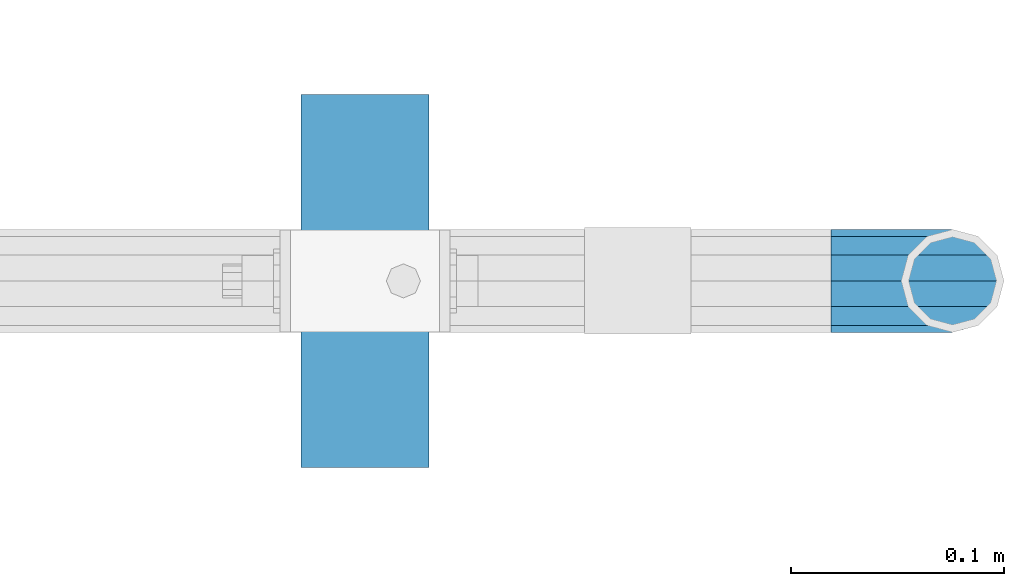
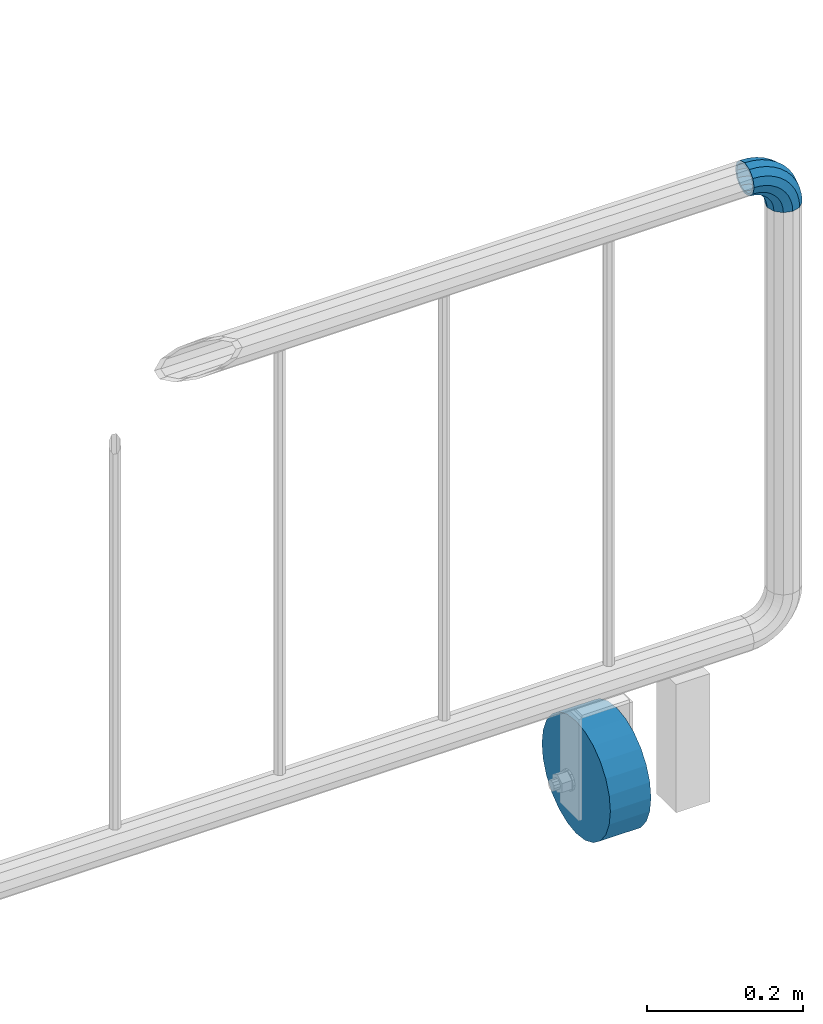
# One storey, part 148 of 208: 1 beam, 1 member.
"""IFC2X3 building model written with IfcOpenShell, lengths in millimetres."""

from ifc_helpers import new_model, si_unit, frame, origin_with_axes, place, context, subcontext, project, spatial, faceted_brep, material, type_object, element, save


model = new_model("IFC2X3")

# Units and contexts
model_context = context("Model", 3, precision=1e-05, world=origin_with_axes())
body_context = subcontext(model_context, "Body", "Model", "MODEL_VIEW")
ifc_project = project(units=[si_unit("LENGTHUNIT", "METRE", prefix="MILLI"), si_unit("AREAUNIT", "SQUARE_METRE"), si_unit("VOLUMEUNIT", "CUBIC_METRE"), si_unit("MASSUNIT", "GRAM", prefix="KILO"), si_unit("TIMEUNIT", "SECOND"), si_unit("PLANEANGLEUNIT", "RADIAN"), si_unit("SOLIDANGLEUNIT", "STERADIAN"), si_unit("THERMODYNAMICTEMPERATUREUNIT", "DEGREE_CELSIUS"), si_unit("LUMINOUSINTENSITYUNIT", "LUMEN")], contexts=[model_context])

# Site, building, storey
site_placement = place(None, origin_with_axes())
site = spatial("IfcSite", under=ifc_project, at=site_placement, CompositionType="ELEMENT")
building_placement = place(site_placement, origin_with_axes())
building = spatial("IfcBuilding", under=site, at=building_placement, Name="Standard", CompositionType="ELEMENT")
storey_placement = place(building_placement, origin_with_axes())
storey = spatial("IfcBuildingStorey", under=building, at=storey_placement, Name="Undefined", CompositionType="ELEMENT", Elevation=0.0)

# Member
ifc_material_1 = material()
member_type = type_object("IfcMemberType", PredefinedType="NOTDEFINED")
member_placement = place(storey_placement, frame((-12177.0539762199, 2941.85399999618, 935.350000000009), z_axis=(0.0, -1.0, 0.0), x_axis=(0.707106781186548, 0.0, -0.707106781186548)))
element("IfcMember", 1, at=member_placement, inside=storey, type_object=member_type, material=ifc_material_1, context=body_context, shape_type="Brep", body=[
    faceted_brep([(17.0766287656552, -17.0766287656552, 0.0), (14.7887943220539, -14.7887943220539, -12.0749999999998), (19.0945697419538, -11.1113146999724, -12.0749999999998), (20.9963409898282, -13.7288782624146, 0.0), (8.53831438282759, -8.53831438282759, -20.9145135013941), (13.8988340683954, -3.95999805533756, -20.9145135013941), (0.0, 0.0, -24.1500000000001), (6.80132714696265, 5.80888215173945, -24.1500000000001), (-8.53831438282759, 8.53831438282759, -20.9145135013941), (-0.296179774470147, 15.5777623588165, -20.9145135013941), (-14.7887943220521, 14.7887943220521, -12.0749999999998), (-5.49191544802852, 22.7290790034513, -12.0749999999998), (-17.0766287656552, 17.0766287656552, 0.0), (-7.39368669589931, 25.3466425658935, 0.0), (-14.7887943220521, 14.7887943220521, 12.0749999999998), (-5.49191544802852, 22.7290790034513, 12.0749999999998), (-8.53831438282759, 8.53831438282759, 20.9145135013941), (-0.296179774470147, 15.5777623588165, 20.9145135013941), (0.0, 0.0, 24.1500000000001), (6.80132714696265, 5.80888215173945, 24.1500000000001), (8.53831438282759, -8.53831438282759, 20.9145135013941), (13.8988340683954, -3.95999805533756, 20.9145135013941), (14.7887943220539, -14.7887943220539, 12.0749999999998), (19.0945697419538, -11.1113146999724, 12.0749999999998), (14.5310443533836, -14.5310443533836, 0.0), (12.5842535535485, -12.5842535535485, 10.2750000000001), (17.2620366843166, -8.58904933077247, 10.2750000000001), (18.8803140815726, -10.8164170826676, 0.0), (7.26552217669268, -7.26552217669268, 17.7968220477701), (12.8408206142685, -2.50376746546499, 17.7968220477701), (0.0, 0.0, 20.5500000000002), (6.80132714696265, 5.80888215173945, 20.5500000000002), (-7.26552217669087, 7.26552217669087, 17.7968220477701), (0.761833679658594, 14.1215317689421, 17.7968220477701), (-12.5842535535485, 12.5842535535485, 10.2750000000001), (-3.65938239039133, 20.2068136342514, 10.2750000000001), (-14.5310443533836, 14.5310443533836, 0.0), (-5.27765978764546, 22.4341813861447, 0.0), (-12.5842535535485, 12.5842535535485, -10.2750000000001), (-3.65938239039133, 20.2068136342514, -10.2750000000001), (-7.26552217669087, 7.26552217669087, -17.7968220477701), (0.761833679658594, 14.1215317689421, -17.7968220477701), (0.0, 0.0, -20.5500000000002), (6.80132714696265, 5.80888215173945, -20.5500000000002), (7.26552217669268, -7.26552217669268, -17.7968220477701), (12.8408206142685, -2.50376746546499, -17.7968220477701), (12.5842535535485, -12.5842535535485, -10.2750000000001), (17.2620366843166, -8.58904933077247, -10.2750000000001), (23.9226184787876, -8.15268262886457, -12.0749999999998), (25.3914986111904, -11.0355222080452, 0.0), (19.9095633268353, -0.27661842847192, -20.9145135013941), (14.4276280424801, 10.482285351105, -24.1500000000001), (8.94569275812501, 21.2411891306783, -20.9145135013941), (4.93263760617265, 29.117253331071, -12.0749999999998), (3.46375747377169, 32.0000929102534, 0.0), (4.93263760617265, 29.117253331071, 12.0749999999998), (8.94569275812501, 21.2411891306783, 20.9145135013941), (14.4276280424801, 10.482285351105, 24.1500000000001), (19.9095633268353, -0.27661842847192, 20.9145135013941), (23.9226184787876, -8.15268262886457, 12.0749999999998), (22.5072161777225, -5.3747992032786, 10.2750000000001), (23.7571328121267, -7.82789872096691, 0.0), (19.0923804273043, 1.32719331506814, 17.7968220477701), (14.4276280424801, 10.482285351105, 20.5500000000002), (9.76287565765597, 19.6373773871383, 17.7968220477701), (6.34803990723776, 26.3393699054886, 10.2750000000001), (5.0981232728318, 28.7924694231751, 0.0), (6.34803990723776, 26.3393699054886, -10.2750000000001), (9.76287565765597, 19.6373773871383, -17.7968220477701), (14.4276280424801, 10.482285351105, -20.5500000000002), (19.0923804273043, 1.32719331506814, -17.7968220477701), (22.5072161777225, -5.3747992032786, -10.2750000000001), (29.1540579492776, -5.98574944945176, -12.0749999999998), (30.1538782624175, -9.06287996733772, 0.0), (26.422498055339, 2.42112746692692, -20.9145135013941), (22.6911178482624, 13.9051349011897, -24.1500000000001), (18.9597376411857, 25.3891423354562, -20.9145135013941), (16.2281777472472, 33.7960192518349, -12.0749999999998), (15.2283574341091, 36.873149769719, 0.0), (16.2281777472472, 33.7960192518349, 12.0749999999998), (18.9597376411857, 25.3891423354562, 20.9145135013941), (22.6911178482624, 13.9051349011897, 24.1500000000001), (26.422498055339, 2.42112746692692, 20.9145135013941), (29.1540579492776, -5.98574944945176, 12.0749999999998), (28.1906383068908, -3.0206486766856, 10.2750000000001), (29.041417082668, -5.63907650867441, 0.0), (25.8662674654661, 4.13302919625858, 17.7968220477701), (22.6911178482624, 13.9051349011897, 20.5500000000002), (19.5159682310605, 23.6772406061227, 17.7968220477701), (17.1915973896339, 30.8309184790687, 10.2750000000001), (16.3408186138568, 33.4493463110575, 0.0), (17.1915973896339, 30.8309184790687, -10.2750000000001), (19.5159682310605, 23.6772406061227, -17.7968220477701), (22.6911178482624, 13.9051349011897, -20.5500000000002), (25.8662674654661, 4.13302919625858, -17.7968220477701), (28.1906383068908, -3.0206486766856, -10.2750000000001), (34.660072751507, -4.66387224825667, -12.0749999999998), (35.1662143510621, -7.85952453908249, 0.0), (33.2772681857005, 4.06681217360347, -20.9145135013941), (31.3883220203406, 15.9931488862876, -24.1500000000001), (29.4993758549808, 27.9194855989754, -20.9145135013941), (28.1165712891743, 36.6501700208355, -12.0749999999998), (27.6104296896192, 39.8458223116613, 0.0), (28.1165712891743, 36.6501700208355, 12.0749999999998), (29.4993758549808, 27.9194855989754, 20.9145135013941), (31.3883220203406, 15.9931488862876, 24.1500000000001), (33.2772681857005, 4.06681217360347, 20.9145135013941), (34.660072751507, -4.66387224825667, 12.0749999999998), (34.1723583568, -1.58456474993909, 10.2750000000001), (34.6030502769172, -4.30384651293934, 0.0), (32.995686148628, 5.84465118667504, 17.7968220477701), (31.3883220203406, 15.9931488862876, 20.5500000000002), (29.7809578920533, 26.1416465859038, 17.7968220477701), (28.6042856838831, 33.5708625225197, 10.2750000000001), (28.1735937637659, 36.29014428552, 0.0), (28.6042856838831, 33.5708625225197, -10.2750000000001), (29.7809578920533, 26.1416465859038, -17.7968220477701), (31.3883220203406, 15.9931488862876, -20.5500000000002), (32.995686148628, 5.84465118667504, -17.7968220477701), (34.1723583568, -1.58456474993909, -10.2750000000001), (40.3050865276346, -4.21960002902779, -12.0749999999998), (40.3050865276346, -7.45508652763237, 0.0), (40.3050865276327, 4.61991347236653, -20.9145135013941), (40.3050865276327, 16.6949134723673, -24.1500000000001), (40.3050865276346, 28.7699134723662, -20.9145135013941), (40.3050865276346, 37.6094269737623, -12.0749999999998), (40.3050865276346, 40.8449134723669, 0.0), (40.3050865276346, 37.6094269737623, 12.0749999999998), (40.3050865276346, 28.7699134723662, 20.9145135013941), (40.3050865276327, 16.6949134723673, 24.1500000000001), (40.3050865276327, 4.61991347236653, 20.9145135013941), (40.3050865276346, -4.21960002902779, 12.0749999999998), (40.3050865276327, -1.10190857540329, 10.2750000000001), (40.3050865276346, -3.85508652763383, 0.0), (40.3050865276346, 6.41991347236763, 17.7968220477701), (40.3050865276327, 16.6949134723673, 20.5500000000002), (40.3050865276346, 26.9699134723669, 17.7968220477701), (40.3050865276346, 34.491735520136, 10.2750000000001), (40.3050865276327, 37.2449134723665, 0.0), (40.3050865276346, 34.491735520136, -10.2750000000001), (40.3050865276346, 26.9699134723669, -17.7968220477701), (40.3050865276327, 16.6949134723673, -20.5500000000002), (40.3050865276346, 6.41991347236763, -17.7968220477701), (40.3050865276327, -1.10190857540329, -10.2750000000001), (45.9501003037603, -4.66387224825485, -12.0749999999998), (45.4439587042052, -7.8595245390843, 0.0), (47.3329048695668, 4.06681217360529, -20.9145135013941), (49.2218510349267, 15.9931488862894, -24.1500000000001), (51.1107972002883, 27.9194855989754, -20.9145135013941), (52.4936017660948, 36.6501700208355, -12.0749999999998), (52.9997433656481, 39.8458223116631, 0.0), (52.4936017660948, 36.6501700208355, 12.0749999999998), (51.1107972002883, 27.9194855989754, 20.9145135013941), (49.2218510349267, 15.9931488862894, 24.1500000000001), (47.3329048695668, 4.06681217360529, 20.9145135013941), (45.9501003037603, -4.66387224825485, 12.0749999999998), (46.4378146984691, -1.58456474993909, 10.2750000000001), (46.0071227783501, -4.30384651294116, 0.0), (47.6144869066393, 5.84465118667322, 17.7968220477701), (49.2218510349267, 15.9931488862894, 20.5500000000002), (50.8292151632158, 26.1416465859038, 17.7968220477701), (52.0058873713861, 33.5708625225197, 10.2750000000001), (52.4365792915032, 36.29014428552, 0.0), (52.0058873713861, 33.5708625225197, -10.2750000000001), (50.8292151632158, 26.1416465859038, -17.7968220477701), (49.2218510349267, 15.9931488862894, -20.5500000000002), (47.6144869066393, 5.84465118667322, -17.7968220477701), (46.4378146984691, -1.58456474993909, -10.2750000000001), (51.4561151059897, -5.98574944945358, -12.0749999999998), (50.4562947928516, -9.06287996733772, 0.0), (54.1876749999301, 2.42112746692692, -20.9145135013941), (57.9190552070068, 13.9051349011897, -24.1500000000001), (61.6504354140834, 25.3891423354562, -20.9145135013941), (64.3819953080219, 33.7960192518349, -12.0749999999998), (65.3818156211601, 36.873149769719, 0.0), (64.3819953080219, 33.7960192518349, 12.0749999999998), (61.6504354140834, 25.3891423354562, 20.9145135013941), (57.9190552070068, 13.9051349011897, 24.1500000000001), (54.1876749999301, 2.42112746692692, 20.9145135013941), (51.4561151059897, -5.98574944945358, 12.0749999999998), (52.4195347483783, -3.0206486766856, 10.2750000000001), (51.5687559726011, -5.63907650867441, 0.0), (54.743905589803, 4.13302919625858, 17.7968220477701), (57.9190552070068, 13.9051349011897, 20.5500000000002), (61.0942048242086, 23.6772406061227, 17.7968220477701), (63.4185756656334, 30.8309184790669, 10.2750000000001), (64.2693544414105, 33.4493463110557, 0.0), (63.4185756656334, 30.8309184790669, -10.2750000000001), (61.0942048242086, 23.6772406061227, -17.7968220477701), (57.9190552070068, 13.9051349011897, -20.5500000000002), (54.743905589803, 4.13302919625858, -17.7968220477701), (52.4195347483783, -3.0206486766856, -10.2750000000001), (56.6875545764815, -8.15268262886457, -12.0749999999998), (55.2186744440787, -11.0355222080452, 0.0), (60.7006097284338, -0.27661842847192, -20.9145135013941), (66.182545012789, 10.482285351105, -24.1500000000001), (71.6644802971441, 21.2411891306783, -20.9145135013941), (75.6775354490965, 29.117253331071, -12.0749999999998), (77.1464155814974, 32.0000929102534, 0.0), (75.6775354490965, 29.117253331071, 12.0749999999998), (71.6644802971441, 21.2411891306783, 20.9145135013941), (66.182545012789, 10.482285351105, 24.1500000000001), (60.7006097284338, -0.27661842847192, 20.9145135013941), (56.6875545764815, -8.15268262886457, 12.0749999999998), (58.1029568775466, -5.3747992032786, 10.2750000000001), (56.8530402431425, -7.82789872096691, 0.0), (61.5177926279648, 1.32719331506814, 17.7968220477701), (66.182545012789, 10.482285351105, 20.5500000000002), (70.8472973976113, 19.6373773871401, 17.7968220477701), (74.2621331480332, 26.3393699054868, 10.2750000000001), (75.5120497824355, 28.7924694231733, 0.0), (74.2621331480332, 26.3393699054868, -10.2750000000001), (70.8472973976113, 19.6373773871401, -17.7968220477701), (66.182545012789, 10.482285351105, -20.5500000000002), (61.5177926279648, 1.32719331506814, -17.7968220477701), (58.1029568775466, -5.3747992032786, -10.2750000000001), (61.5156033133135, -11.1113146999742, -12.0749999999998), (59.6138320654427, -13.7288782624164, 0.0), (66.7113389868737, -3.95999805533756, -20.9145135013941), (73.8088459083046, 5.80888215173763, -24.1500000000001), (80.9063528297374, 15.5777623588183, -20.9145135013941), (86.1020885032976, 22.7290790034513, -12.0749999999998), (88.0038597511684, 25.3466425658935, 0.0), (86.1020885032976, 22.7290790034513, 12.0749999999998), (80.9063528297374, 15.5777623588183, 20.9145135013941), (73.8088459083046, 5.80888215173763, 24.1500000000001), (66.7113389868737, -3.95999805533756, 20.9145135013941), (61.5156033133135, -11.1113146999742, 12.0749999999998), (63.3481363709525, -8.58904933077247, 10.2750000000001), (61.7298589736947, -10.8164170826658, 0.0), (67.7693524409988, -2.50376746546317, 17.7968220477701), (73.8088459083046, 5.80888215173763, 20.5500000000002), (79.8483393756105, 14.1215317689421, 17.7968220477701), (84.2695554456586, 20.2068136342532, 10.2750000000001), (85.8878328429146, 22.4341813861447, 0.0), (84.2695554456586, 20.2068136342532, -10.2750000000001), (79.8483393756105, 14.1215317689421, -17.7968220477701), (73.8088459083046, 5.80888215173763, -20.5500000000002), (67.7693524409988, -2.50376746546317, -17.7968220477701), (63.3481363709525, -8.58904933077247, -10.2750000000001), (65.8213787332152, -14.7887943220539, -12.0749999999998), (63.5335442896121, -17.0766287656534, 0.0), (72.0718586724379, -8.53831438282759, -20.9145135013941), (80.6101730552673, 1.81898940354586e-12, -24.1500000000001), (89.1484874380967, 8.53831438282759, -20.9145135013941), (95.3989673773231, 14.7887943220539, -12.0749999999998), (97.6868018209225, 17.0766287656534, 0.0), (95.3989673773231, 14.7887943220539, 12.0749999999998), (89.1484874380967, 8.53831438282759, 20.9145135013941), (80.6101730552673, 1.81898940354586e-12, 24.1500000000001), (72.0718586724379, -8.53831438282759, 20.9145135013941), (65.8213787332152, -14.7887943220539, 12.0749999999998), (68.0259195017188, -12.5842535535503, 10.2750000000001), (66.0791287018856, -14.5310443533836, 0.0), (73.3446508785764, -7.26552217669268, 17.7968220477701), (80.6101730552673, 1.81898940354586e-12, 20.5500000000002), (87.8756952319582, 7.26552217669268, 17.7968220477701), (93.1944266088158, 12.5842535535503, 10.2750000000001), (95.141217408649, 14.5310443533836, 0.0), (93.1944266088158, 12.5842535535503, -10.2750000000001), (87.8756952319582, 7.26552217669268, -17.7968220477701), (80.6101730552673, 1.81898940354586e-12, -20.5500000000002), (73.3446508785764, -7.26552217669268, -17.7968220477701), (68.0259195017188, -12.5842535535503, -10.2750000000001)], [[[0, 1, 2, 3]], [[1, 4, 5, 2]], [[4, 6, 7, 5]], [[6, 8, 9, 7]], [[8, 10, 11, 9]], [[10, 12, 13, 11]], [[12, 14, 15, 13]], [[14, 16, 17, 15]], [[16, 18, 19, 17]], [[18, 20, 21, 19]], [[20, 22, 23, 21]], [[22, 0, 3, 23]], [[24, 25, 26, 27]], [[25, 28, 29, 26]], [[28, 30, 31, 29]], [[30, 32, 33, 31]], [[32, 34, 35, 33]], [[34, 36, 37, 35]], [[36, 38, 39, 37]], [[38, 40, 41, 39]], [[40, 42, 43, 41]], [[42, 44, 45, 43]], [[44, 46, 47, 45]], [[46, 24, 27, 47]], [[22, 20, 18, 16, 14, 12, 10, 8, 6, 4, 1, 0], [46, 44, 42, 40, 38, 36, 34, 32, 30, 28, 25, 24]], [[3, 2, 48, 49]], [[2, 5, 50, 48]], [[5, 7, 51, 50]], [[7, 9, 52, 51]], [[9, 11, 53, 52]], [[11, 13, 54, 53]], [[13, 15, 55, 54]], [[15, 17, 56, 55]], [[17, 19, 57, 56]], [[19, 21, 58, 57]], [[21, 23, 59, 58]], [[23, 3, 49, 59]], [[27, 26, 60, 61]], [[26, 29, 62, 60]], [[29, 31, 63, 62]], [[31, 33, 64, 63]], [[33, 35, 65, 64]], [[35, 37, 66, 65]], [[37, 39, 67, 66]], [[39, 41, 68, 67]], [[41, 43, 69, 68]], [[43, 45, 70, 69]], [[45, 47, 71, 70]], [[47, 27, 61, 71]], [[49, 48, 72, 73]], [[48, 50, 74, 72]], [[50, 51, 75, 74]], [[51, 52, 76, 75]], [[52, 53, 77, 76]], [[53, 54, 78, 77]], [[54, 55, 79, 78]], [[55, 56, 80, 79]], [[56, 57, 81, 80]], [[57, 58, 82, 81]], [[58, 59, 83, 82]], [[59, 49, 73, 83]], [[61, 60, 84, 85]], [[60, 62, 86, 84]], [[62, 63, 87, 86]], [[63, 64, 88, 87]], [[64, 65, 89, 88]], [[65, 66, 90, 89]], [[66, 67, 91, 90]], [[67, 68, 92, 91]], [[68, 69, 93, 92]], [[69, 70, 94, 93]], [[70, 71, 95, 94]], [[71, 61, 85, 95]], [[73, 72, 96, 97]], [[72, 74, 98, 96]], [[74, 75, 99, 98]], [[75, 76, 100, 99]], [[76, 77, 101, 100]], [[77, 78, 102, 101]], [[78, 79, 103, 102]], [[79, 80, 104, 103]], [[80, 81, 105, 104]], [[81, 82, 106, 105]], [[82, 83, 107, 106]], [[83, 73, 97, 107]], [[85, 84, 108, 109]], [[84, 86, 110, 108]], [[86, 87, 111, 110]], [[87, 88, 112, 111]], [[88, 89, 113, 112]], [[89, 90, 114, 113]], [[90, 91, 115, 114]], [[91, 92, 116, 115]], [[92, 93, 117, 116]], [[93, 94, 118, 117]], [[94, 95, 119, 118]], [[95, 85, 109, 119]], [[97, 96, 120, 121]], [[96, 98, 122, 120]], [[98, 99, 123, 122]], [[99, 100, 124, 123]], [[100, 101, 125, 124]], [[101, 102, 126, 125]], [[102, 103, 127, 126]], [[103, 104, 128, 127]], [[104, 105, 129, 128]], [[105, 106, 130, 129]], [[106, 107, 131, 130]], [[107, 97, 121, 131]], [[109, 108, 132, 133]], [[108, 110, 134, 132]], [[110, 111, 135, 134]], [[111, 112, 136, 135]], [[112, 113, 137, 136]], [[113, 114, 138, 137]], [[114, 115, 139, 138]], [[115, 116, 140, 139]], [[116, 117, 141, 140]], [[117, 118, 142, 141]], [[118, 119, 143, 142]], [[119, 109, 133, 143]], [[121, 120, 144, 145]], [[120, 122, 146, 144]], [[122, 123, 147, 146]], [[123, 124, 148, 147]], [[124, 125, 149, 148]], [[125, 126, 150, 149]], [[126, 127, 151, 150]], [[127, 128, 152, 151]], [[128, 129, 153, 152]], [[129, 130, 154, 153]], [[130, 131, 155, 154]], [[131, 121, 145, 155]], [[133, 132, 156, 157]], [[132, 134, 158, 156]], [[134, 135, 159, 158]], [[135, 136, 160, 159]], [[136, 137, 161, 160]], [[137, 138, 162, 161]], [[138, 139, 163, 162]], [[139, 140, 164, 163]], [[140, 141, 165, 164]], [[141, 142, 166, 165]], [[142, 143, 167, 166]], [[143, 133, 157, 167]], [[145, 144, 168, 169]], [[144, 146, 170, 168]], [[146, 147, 171, 170]], [[147, 148, 172, 171]], [[148, 149, 173, 172]], [[149, 150, 174, 173]], [[150, 151, 175, 174]], [[151, 152, 176, 175]], [[152, 153, 177, 176]], [[153, 154, 178, 177]], [[154, 155, 179, 178]], [[155, 145, 169, 179]], [[157, 156, 180, 181]], [[156, 158, 182, 180]], [[158, 159, 183, 182]], [[159, 160, 184, 183]], [[160, 161, 185, 184]], [[161, 162, 186, 185]], [[162, 163, 187, 186]], [[163, 164, 188, 187]], [[164, 165, 189, 188]], [[165, 166, 190, 189]], [[166, 167, 191, 190]], [[167, 157, 181, 191]], [[169, 168, 192, 193]], [[168, 170, 194, 192]], [[170, 171, 195, 194]], [[171, 172, 196, 195]], [[172, 173, 197, 196]], [[173, 174, 198, 197]], [[174, 175, 199, 198]], [[175, 176, 200, 199]], [[176, 177, 201, 200]], [[177, 178, 202, 201]], [[178, 179, 203, 202]], [[179, 169, 193, 203]], [[181, 180, 204, 205]], [[180, 182, 206, 204]], [[182, 183, 207, 206]], [[183, 184, 208, 207]], [[184, 185, 209, 208]], [[185, 186, 210, 209]], [[186, 187, 211, 210]], [[187, 188, 212, 211]], [[188, 189, 213, 212]], [[189, 190, 214, 213]], [[190, 191, 215, 214]], [[191, 181, 205, 215]], [[193, 192, 216, 217]], [[192, 194, 218, 216]], [[194, 195, 219, 218]], [[195, 196, 220, 219]], [[196, 197, 221, 220]], [[197, 198, 222, 221]], [[198, 199, 223, 222]], [[199, 200, 224, 223]], [[200, 201, 225, 224]], [[201, 202, 226, 225]], [[202, 203, 227, 226]], [[203, 193, 217, 227]], [[205, 204, 228, 229]], [[204, 206, 230, 228]], [[206, 207, 231, 230]], [[207, 208, 232, 231]], [[208, 209, 233, 232]], [[209, 210, 234, 233]], [[210, 211, 235, 234]], [[211, 212, 236, 235]], [[212, 213, 237, 236]], [[213, 214, 238, 237]], [[214, 215, 239, 238]], [[215, 205, 229, 239]], [[217, 216, 240, 241]], [[216, 218, 242, 240]], [[218, 219, 243, 242]], [[219, 220, 244, 243]], [[220, 221, 245, 244]], [[221, 222, 246, 245]], [[222, 223, 247, 246]], [[223, 224, 248, 247]], [[224, 225, 249, 248]], [[225, 226, 250, 249]], [[226, 227, 251, 250]], [[227, 217, 241, 251]], [[229, 228, 252, 253]], [[228, 230, 254, 252]], [[230, 231, 255, 254]], [[231, 232, 256, 255]], [[232, 233, 257, 256]], [[233, 234, 258, 257]], [[234, 235, 259, 258]], [[235, 236, 260, 259]], [[236, 237, 261, 260]], [[237, 238, 262, 261]], [[238, 239, 263, 262]], [[239, 229, 253, 263]], [[242, 243, 244, 245, 246, 247, 248, 249, 250, 251, 241, 240], [254, 255, 256, 257, 258, 259, 260, 261, 262, 263, 253, 252]]]),
])

# Beam
ifc_material_2 = material()
beam_type = type_object("IfcBeamType", PredefinedType="NOTDEFINED")
beam_placement = place(storey_placement, frame((-12365.9039762196, 2941.85399999618, 87.5000130887838), z_axis=(0.0, 0.0, 1.0), x_axis=(-1.0, 0.0, 0.0)))
element("IfcBeam", 2, at=beam_placement, inside=storey, type_object=beam_type, material=ifc_material_2, context=body_context, shape_type="Brep", body=[
    faceted_brep([(0.0, -87.5, 0.0), (0.0, -84.5185098002935, -22.6466664464706), (60.0, -84.5185098002935, -22.6466664464706), (60.0, -87.5, 0.0), (0.0, -75.7772228311383, -43.75), (60.0, -75.7772228311383, -43.75), (0.0, -61.8718433538229, -61.8718433538229), (60.0, -61.8718433538229, -61.8718433538229), (0.0, -43.75, -75.7772228311384), (60.0, -43.75, -75.7772228311384), (0.0, -22.6466664464706, -84.5185098002935), (60.0, -22.6466664464706, -84.5185098002935), (0.0, 0.0, -87.5), (60.0, 0.0, -87.5), (0.0, 22.6466664464706, -84.5185098002935), (60.0, 22.6466664464706, -84.5185098002935), (0.0, 43.75, -75.7772228311384), (60.0, 43.75, -75.7772228311384), (0.0, 61.8718433538229, -61.8718433538229), (60.0, 61.8718433538229, -61.8718433538229), (0.0, 75.7772228311383, -43.75), (60.0, 75.7772228311383, -43.75), (0.0, 84.5185098002935, -22.6466664464705), (60.0, 84.5185098002935, -22.6466664464705), (0.0, 87.5, 1.4210854715202e-14), (60.0, 87.5, 1.4210854715202e-14), (0.0, 84.5185098002935, 22.6466664464706), (60.0, 84.5185098002935, 22.6466664464706), (0.0, 75.7772228311383, 43.75), (60.0, 75.7772228311383, 43.75), (0.0, 61.8718433538229, 61.8718433538229), (60.0, 61.8718433538229, 61.8718433538229), (0.0, 43.75, 75.7772228311384), (60.0, 43.75, 75.7772228311384), (0.0, 22.6466664464706, 84.5185098002935), (60.0, 22.6466664464706, 84.5185098002935), (0.0, 0.0, 87.5), (60.0, 0.0, 87.5), (0.0, -22.6466664464706, 84.5185098002935), (60.0, -22.6466664464706, 84.5185098002935), (0.0, -43.75, 75.7772228311384), (60.0, -43.75, 75.7772228311384), (0.0, -61.8718433538229, 61.8718433538229), (60.0, -61.8718433538229, 61.8718433538229), (0.0, -75.7772228311383, 43.75), (60.0, -75.7772228311383, 43.75), (0.0, -84.5185098002935, 22.6466664464706), (60.0, -84.5185098002935, 22.6466664464706)], [[[0, 1, 2, 3]], [[1, 4, 5, 2]], [[4, 6, 7, 5]], [[6, 8, 9, 7]], [[8, 10, 11, 9]], [[10, 12, 13, 11]], [[12, 14, 15, 13]], [[14, 16, 17, 15]], [[16, 18, 19, 17]], [[18, 20, 21, 19]], [[20, 22, 23, 21]], [[22, 24, 25, 23]], [[24, 26, 27, 25]], [[26, 28, 29, 27]], [[28, 30, 31, 29]], [[30, 32, 33, 31]], [[32, 34, 35, 33]], [[34, 36, 37, 35]], [[36, 38, 39, 37]], [[38, 40, 41, 39]], [[40, 42, 43, 41]], [[42, 44, 45, 43]], [[44, 46, 47, 45]], [[46, 0, 3, 47]], [[5, 7, 9, 11, 13, 15, 17, 19, 21, 23, 25, 27, 29, 31, 33, 35, 37, 39, 41, 43, 45, 47, 3, 2]], [[46, 44, 42, 40, 38, 36, 34, 32, 30, 28, 26, 24, 22, 20, 18, 16, 14, 12, 10, 8, 6, 4, 1, 0]]]),
])

save(model, "model.ifc")
